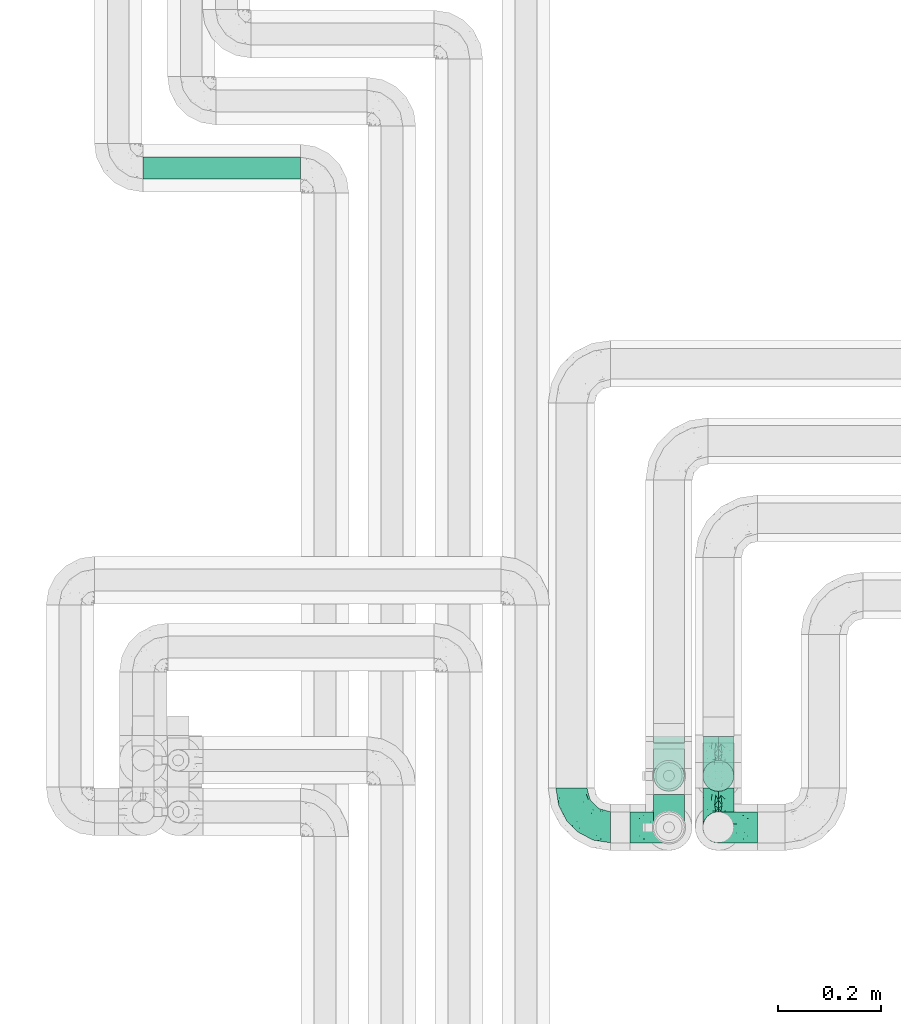
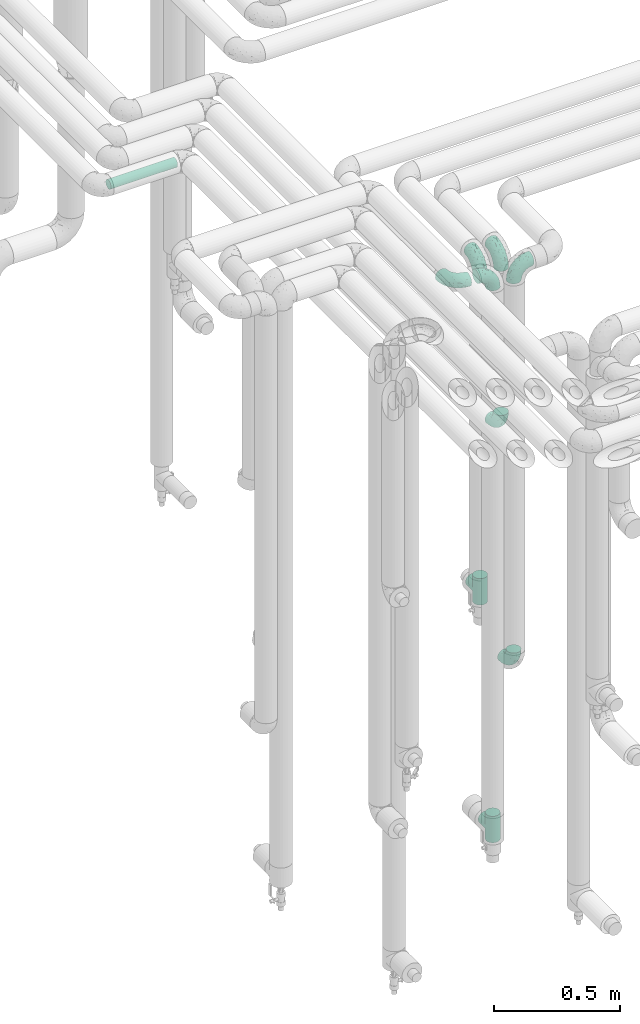
# One storey, part 633 of 827: 9 flow fittings, 1 flow segment.
"""IFC2X3 building model written with IfcOpenShell, lengths in millimetres."""

from ifc_helpers import new_model, entity, si_unit, converted_unit, derived_unit, direction, frame, origin, origin_2d_with_axis, place, context, subcontext, project, spatial, circle, extrude, faceted_brep, source, transform, mapped, material, type_object, type_shapes, element, save


model = new_model("IFC2X3")

# Units and contexts
model_context = context("Model", 3, precision=0.01, world=origin(), true_north=direction((6.12303176911189e-17, 1.0)))
body_context = subcontext(model_context, "Body", "Model", "MODEL_VIEW")
ifc_project = project(units=[si_unit("LENGTHUNIT", "METRE", prefix="MILLI"), si_unit("AREAUNIT", "SQUARE_METRE"), si_unit("VOLUMEUNIT", "CUBIC_METRE"), converted_unit("PLANEANGLEUNIT", "DEGREE", entity("IfcRatioMeasure", 0.0174532925199433), si_unit("PLANEANGLEUNIT", "RADIAN"), dimensions=[0, 0, 0, 0, 0, 0, 0]), si_unit("MASSUNIT", "GRAM", prefix="KILO"), derived_unit("MASSDENSITYUNIT", [(si_unit("MASSUNIT", "GRAM", prefix="KILO"), 1), (si_unit("LENGTHUNIT", "METRE"), -3)]), derived_unit("MOMENTOFINERTIAUNIT", [(si_unit("LENGTHUNIT", "METRE"), 4)]), si_unit("TIMEUNIT", "SECOND"), si_unit("FREQUENCYUNIT", "HERTZ"), si_unit("THERMODYNAMICTEMPERATUREUNIT", "DEGREE_CELSIUS"), derived_unit("THERMALTRANSMITTANCEUNIT", [(si_unit("MASSUNIT", "GRAM", prefix="KILO"), 1), (si_unit("THERMODYNAMICTEMPERATUREUNIT", "KELVIN"), -1), (si_unit("TIMEUNIT", "SECOND"), -3)]), derived_unit("VOLUMETRICFLOWRATEUNIT", [(si_unit("LENGTHUNIT", "METRE"), 3), (si_unit("TIMEUNIT", "SECOND"), -1)]), derived_unit("MASSFLOWRATEUNIT", [(si_unit("MASSUNIT", "GRAM", prefix="KILO"), 1), (si_unit("TIMEUNIT", "SECOND"), -1)]), derived_unit("ROTATIONALFREQUENCYUNIT", [(si_unit("TIMEUNIT", "SECOND"), -1)]), si_unit("ELECTRICCURRENTUNIT", "AMPERE"), si_unit("ELECTRICVOLTAGEUNIT", "VOLT"), si_unit("POWERUNIT", "WATT"), si_unit("FORCEUNIT", "NEWTON", prefix="KILO"), si_unit("ILLUMINANCEUNIT", "LUX"), si_unit("LUMINOUSFLUXUNIT", "LUMEN"), si_unit("LUMINOUSINTENSITYUNIT", "CANDELA"), derived_unit("USERDEFINED", [(si_unit("MASSUNIT", "GRAM", prefix="KILO"), -1), (si_unit("LENGTHUNIT", "METRE"), -2), (si_unit("TIMEUNIT", "SECOND"), 3), (si_unit("LUMINOUSFLUXUNIT", "LUMEN"), 1)]), derived_unit("LINEARVELOCITYUNIT", [(si_unit("LENGTHUNIT", "METRE"), 1), (si_unit("TIMEUNIT", "SECOND"), -1)]), si_unit("PRESSUREUNIT", "PASCAL"), derived_unit("USERDEFINED", [(si_unit("LENGTHUNIT", "METRE"), -2), (si_unit("MASSUNIT", "GRAM", prefix="KILO"), 1), (si_unit("TIMEUNIT", "SECOND"), -2)]), derived_unit("LINEARFORCEUNIT", [(si_unit("MASSUNIT", "GRAM", prefix="KILO"), 1), (si_unit("LENGTHUNIT", "METRE"), 1), (si_unit("TIMEUNIT", "SECOND"), -2), (si_unit("LENGTHUNIT", "METRE"), -1)]), derived_unit("PLANARFORCEUNIT", [(si_unit("MASSUNIT", "GRAM", prefix="KILO"), 1), (si_unit("LENGTHUNIT", "METRE"), 1), (si_unit("TIMEUNIT", "SECOND"), -2), (si_unit("LENGTHUNIT", "METRE"), -2)])], contexts=[model_context])

# Site, building, storey
site_placement = place(None, origin())
site = spatial("IfcSite", under=ifc_project, at=site_placement, CompositionType="ELEMENT")
building_placement = place(site_placement, origin())
building = spatial("IfcBuilding", under=site, at=building_placement, CompositionType="ELEMENT")
storey_placement = place(building_placement, frame((0.0, 0.0, 28200.0)))
storey = spatial("IfcBuildingStorey", under=building, at=storey_placement, Name="08", CompositionType="ELEMENT", Elevation=28200.0)

# Flow segment
pipe_segment_type = type_object("IfcPipeSegmentType", PredefinedType="NOTDEFINED")
flow_segment_placement = place(storey_placement, frame((30563.05, 16968.46, 2977.25)))
element("IfcFlowSegment", 1, at=flow_segment_placement, inside=storey, type_object=pipe_segment_type, context=body_context, shape_type="SweptSolid", body=[
    extrude(circle(Radius=21.15, at=origin_2d_with_axis()), frame((0.0, 22.75, 22.75), z_axis=(1.0, 0.0, 0.0), x_axis=(0.0, -1.0, 0.0)), (0.0, 0.0, 1.0), 305.473199999971),
])

# Flow fittings
ifc_material = material()
pipe_fitting_type_1 = type_object("IfcPipeFittingType", Name="ADSK_1", PredefinedType="NOTDEFINED", material=ifc_material)
shared_shape_1 = source(origin(), body_context, "Body", "Brep", [
    faceted_brep([(-76.0, 15.07, -26.11), (-76.0, 7.8, -29.12), (-76.0, 0.0, -30.15), (-76.0, -7.8, -29.12), (-76.0, -15.08, -26.11), (-76.0, -21.32, -21.32), (-76.0, -26.11, -15.08), (-76.0, -29.12, -7.8), (-76.0, -30.15, 0.0), (-76.0, -29.12, 7.8), (-76.0, -26.11, 15.07), (-76.0, -21.32, 21.32), (-76.0, -15.08, 26.11), (-76.0, -7.8, 29.12), (-76.0, 0.0, 30.15), (-76.0, 7.8, 29.12), (-76.0, 15.07, 26.11), (-76.0, 21.32, 21.32), (-76.0, 26.11, 15.07), (-76.0, 29.12, 7.8), (-76.0, 30.15, 0.0), (-76.0, 29.12, -7.8), (-76.0, 26.11, -15.08), (-76.0, 21.32, -21.32), (0.0, 76.0, -30.15), (-7.8, 76.0, -29.12), (-15.07, 76.0, -26.11), (-21.32, 76.0, -21.32), (-26.11, 76.0, -15.08), (-29.12, 76.0, -7.8), (-30.15, 76.0, 0.0), (-29.12, 76.0, 7.8), (-26.11, 76.0, 15.07), (-21.32, 76.0, 21.32), (-15.07, 76.0, 26.11), (-7.8, 76.0, 29.12), (0.0, 76.0, 30.15), (7.8, 76.0, 29.12), (15.08, 76.0, 26.11), (21.32, 76.0, 21.32), (26.11, 76.0, 15.07), (29.12, 76.0, 7.8), (30.15, 76.0, 0.0), (29.12, 76.0, -7.8), (26.11, 76.0, -15.08), (21.32, 76.0, -21.32), (15.08, 76.0, -26.11), (7.8, 76.0, -29.12), (10.79, 31.43, 21.07), (4.32, 31.7, 25.72), (1.65, 15.19, 19.92), (-61.17, -27.8, 0.0), (-51.1, -25.49, 9.84), (-56.14, -10.61, 27.27), (-31.7, -4.32, 25.72), (-39.75, 1.72, 29.41), (-43.2, -24.95, 0.0), (-1.86, 1.86, 0.0), (4.49, 7.65, 5.78), (-7.82, -4.61, 5.83), (-56.21, -22.79, 17.21), (-58.98, -3.38, 29.7), (-53.96, 5.6, 30.07), (-10.86, 10.86, 25.48), (-17.2, -2.6, 20.44), (-49.15, -16.01, 22.7), (-22.18, -14.24, 7.99), (-28.4, -17.42, 0.0), (-13.61, -9.88, 0.0), (-39.0, 23.48, 27.76), (-58.76, 12.54, 28.36), (-41.61, 15.41, 29.48), (16.01, 49.15, 22.7), (-58.55, 25.93, 19.53), (-51.53, 33.5, 13.51), (-64.92, 28.76, 12.4), (-7.48, 23.14, 28.25), (-1.72, 39.75, 29.41), (-12.04, 27.88, 29.88), (-63.91, 18.81, 24.52), (-11.63, 65.16, 28.18), (-4.97, 57.02, 30.05), (9.88, 13.61, 0.0), (-62.5, 31.74, 5.02), (-45.17, 30.98, 21.2), (-21.78, 9.76, 28.58), (10.61, 56.14, 27.27), (-32.09, 54.42, 13.26), (22.79, 56.21, 17.21), (15.38, 31.17, 15.63), (25.49, 51.1, 9.84), (21.84, 36.35, 5.92), (24.95, 43.2, 0.0), (3.38, 58.98, 29.7), (-31.17, -15.38, 15.63), (-39.39, 41.78, 15.45), (-34.56, 41.13, 20.79), (-39.81, -23.25, 5.49), (27.8, 61.17, 0.0), (-31.74, 62.5, 5.02), (-53.07, 36.29, 0.0), (-42.95, 42.95, 7.29), (-36.29, 53.07, 0.0), (-19.83, 58.51, 24.79), (-25.48, 60.2, 19.41), (-14.53, 50.96, 28.57), (-13.31, 37.09, 30.07), (-26.16, 40.06, 26.4), (-32.43, -10.35, 21.9), (17.42, 28.4, 0.0), (14.24, 22.18, 7.99), (-38.67, 9.72, 30.15), (-24.66, 17.36, 30.09), (-37.08, 31.49, 24.99), (-49.27, 22.83, 25.24), (-20.8, 38.81, 28.63), (-27.58, 27.58, 29.2), (-36.07, -20.23, 10.71), (-15.19, -6.16, 14.9), (6.6, 15.4, 14.49), (-2.51, 2.51, 11.35), (-65.16, 11.63, -28.18), (-49.15, -16.01, -22.7), (-57.02, 4.97, -30.05), (-25.93, 58.55, -19.53), (-33.5, 51.53, -13.51), (-28.76, 64.92, -12.4), (-60.2, 25.48, -19.41), (-58.51, 19.83, -24.79), (4.61, 7.82, -5.83), (-7.65, -4.49, -5.78), (-2.51, 2.51, -11.35), (-62.5, 31.74, -5.02), (-50.96, 14.53, -28.57), (-37.09, 13.31, -30.07), (-42.95, 42.95, -7.29), (25.49, 51.1, -9.84), (22.79, 56.21, -17.21), (-40.06, 26.16, -26.4), (3.38, 58.98, -29.7), (-5.6, 53.96, -30.07), (-27.88, 12.04, -29.88), (-9.76, 21.78, -28.58), (-23.14, 7.48, -28.25), (-51.1, -25.49, -9.84), (15.38, 31.17, -15.63), (16.01, 49.15, -22.7), (-23.48, 39.0, -27.76), (-12.54, 58.76, -28.36), (-15.41, 41.61, -29.48), (-56.21, -22.79, -17.21), (-9.72, 38.67, -30.15), (-17.36, 24.66, -30.09), (-22.18, -14.24, -7.99), (-41.13, 34.56, -20.79), (-31.74, 62.5, -5.02), (-58.98, -3.38, -29.7), (-31.17, -15.38, -15.63), (-56.14, -10.61, -27.27), (14.24, 22.18, -7.99), (23.25, 39.81, -5.49), (-31.49, 37.08, -24.99), (-15.19, -6.16, -14.9), (1.65, 15.19, -19.92), (-18.81, 63.91, -24.52), (-32.59, -11.62, -20.84), (-31.7, -4.32, -25.72), (-17.2, -2.6, -20.44), (-39.75, 1.72, -29.41), (-54.42, 32.09, -13.26), (-30.98, 45.17, -21.2), (10.61, 56.14, -27.27), (10.23, 31.31, -21.52), (4.32, 31.7, -25.72), (-41.78, 39.39, -15.45), (-1.72, 39.75, -29.41), (-36.35, -21.84, -5.92), (-22.83, 49.27, -25.24), (-38.81, 20.8, -28.63), (-27.58, 27.58, -29.2), (-10.86, 10.86, -25.48), (20.23, 36.07, -10.71), (6.6, 15.4, -14.49)], [[[0, 1, 2, 3, 4, 5, 6, 7, 8, 9, 10, 11, 12, 13, 14, 15, 16, 17, 18, 19, 20, 21, 22, 23]], [[24, 25, 26, 27, 28, 29, 30, 31, 32, 33, 34, 35, 36, 37, 38, 39, 40, 41, 42, 43, 44, 45, 46, 47]], [[48, 49, 50]], [[51, 52, 9]], [[53, 54, 55]], [[9, 52, 10]], [[56, 52, 51]], [[57, 58, 59]], [[11, 10, 60]], [[14, 61, 62]], [[63, 54, 64]], [[65, 12, 11]], [[65, 53, 12]], [[66, 67, 68]], [[69, 70, 71]], [[72, 39, 38]], [[73, 74, 75]], [[15, 70, 16]], [[76, 77, 78]], [[16, 79, 17]], [[13, 61, 14]], [[35, 80, 81]], [[14, 62, 15]], [[17, 73, 18]], [[57, 82, 58]], [[20, 19, 83]], [[75, 19, 18]], [[70, 15, 62]], [[73, 84, 74]], [[78, 85, 76]], [[38, 86, 72]], [[32, 31, 87]], [[88, 89, 90]], [[91, 92, 90]], [[72, 86, 49]], [[36, 93, 37]], [[75, 83, 19]], [[36, 35, 81]], [[60, 94, 65]], [[40, 90, 41]], [[95, 96, 87]], [[88, 90, 40]], [[66, 97, 67]], [[90, 98, 41]], [[40, 39, 88]], [[99, 31, 30]], [[20, 83, 100]], [[101, 102, 100]], [[52, 60, 10]], [[102, 99, 30]], [[96, 103, 104]], [[83, 101, 100]], [[12, 53, 13]], [[104, 103, 33]], [[105, 106, 81]], [[107, 105, 103]], [[64, 54, 108]], [[80, 103, 105]], [[80, 35, 34]], [[34, 33, 103]], [[86, 38, 37]], [[109, 110, 82]], [[71, 111, 112]], [[69, 107, 113]], [[79, 73, 17]], [[114, 113, 84]], [[33, 32, 104]], [[115, 107, 116]], [[105, 115, 106]], [[93, 81, 77]], [[54, 53, 65]], [[61, 53, 55]], [[108, 94, 64]], [[54, 63, 85]], [[93, 86, 37]], [[77, 76, 49]], [[77, 49, 86]], [[49, 63, 50]], [[60, 52, 117]], [[65, 11, 60]], [[39, 72, 88]], [[89, 88, 72]], [[71, 70, 62]], [[79, 70, 114]], [[103, 96, 107]], [[69, 113, 114]], [[112, 106, 116]], [[77, 81, 106]], [[112, 116, 71]], [[112, 55, 85]], [[64, 50, 63]], [[57, 59, 68]], [[32, 87, 104]], [[96, 104, 87]], [[94, 118, 64]], [[50, 119, 89]], [[50, 64, 118]], [[50, 89, 48]], [[81, 93, 36]], [[86, 93, 77]], [[53, 61, 13]], [[62, 61, 55]], [[71, 62, 111]], [[69, 71, 116]], [[95, 101, 74]], [[99, 101, 87]], [[118, 66, 59]], [[117, 97, 66]], [[117, 66, 94]], [[91, 89, 110]], [[91, 110, 109]], [[110, 89, 119]], [[9, 8, 51]], [[98, 90, 92]], [[98, 42, 41]], [[101, 83, 74]], [[101, 99, 102]], [[87, 31, 99]], [[62, 55, 111]], [[55, 112, 111]], [[107, 69, 116]], [[70, 69, 114]], [[107, 96, 113]], [[84, 113, 96]], [[84, 96, 95]], [[114, 84, 73]], [[70, 79, 16]], [[73, 79, 114]], [[54, 85, 55]], [[76, 85, 63]], [[49, 76, 63]], [[77, 106, 78]], [[106, 112, 78]], [[85, 78, 112]], [[73, 75, 18]], [[83, 75, 74]], [[103, 80, 34]], [[81, 80, 105]], [[101, 95, 87]], [[84, 95, 74]], [[106, 115, 116]], [[105, 107, 115]], [[120, 59, 58]], [[82, 110, 58]], [[119, 58, 110]], [[118, 59, 120]], [[66, 68, 59]], [[54, 65, 108]], [[94, 108, 65]], [[66, 118, 94]], [[50, 118, 120]], [[50, 120, 119]], [[119, 120, 58]], [[89, 72, 48]], [[49, 48, 72]], [[60, 117, 94]], [[117, 52, 97]], [[52, 56, 97]], [[67, 97, 56]], [[92, 91, 109]], [[89, 91, 90]], [[121, 1, 0]], [[122, 5, 4]], [[2, 1, 123]], [[124, 125, 126]], [[127, 128, 23]], [[129, 130, 131]], [[100, 132, 20]], [[133, 134, 123]], [[135, 100, 102]], [[136, 137, 44]], [[133, 128, 138]], [[24, 139, 140]], [[141, 142, 143]], [[121, 128, 133]], [[6, 144, 7]], [[137, 145, 146]], [[144, 51, 7]], [[147, 148, 149]], [[144, 6, 150]], [[149, 151, 152]], [[153, 68, 67]], [[154, 128, 127]], [[30, 155, 102]], [[43, 42, 98]], [[156, 3, 2]], [[157, 144, 150]], [[158, 4, 3]], [[24, 140, 25]], [[155, 135, 102]], [[159, 160, 109]], [[30, 29, 155]], [[147, 138, 161]], [[27, 124, 28]], [[57, 129, 82]], [[162, 163, 131]], [[27, 26, 164]], [[148, 26, 25]], [[165, 166, 167]], [[24, 47, 139]], [[143, 168, 141]], [[22, 21, 169]], [[125, 124, 170]], [[148, 25, 140]], [[46, 146, 171]], [[158, 122, 4]], [[0, 23, 128]], [[1, 121, 123]], [[109, 82, 159]], [[45, 44, 137]], [[146, 46, 45]], [[136, 43, 98]], [[132, 21, 20]], [[136, 98, 92]], [[172, 173, 146]], [[46, 171, 47]], [[43, 136, 44]], [[174, 154, 169]], [[171, 173, 175]], [[6, 5, 150]], [[126, 29, 28]], [[176, 56, 144]], [[122, 158, 166]], [[164, 124, 27]], [[177, 161, 170]], [[23, 22, 127]], [[178, 138, 179]], [[133, 178, 134]], [[156, 123, 168]], [[156, 158, 3]], [[168, 143, 166]], [[168, 166, 158]], [[166, 180, 167]], [[173, 171, 146]], [[139, 171, 175]], [[172, 145, 163]], [[173, 180, 142]], [[5, 122, 150]], [[157, 150, 122]], [[137, 136, 181]], [[146, 45, 137]], [[149, 148, 140]], [[164, 148, 177]], [[128, 154, 138]], [[147, 161, 177]], [[152, 134, 179]], [[168, 123, 134]], [[152, 179, 149]], [[152, 175, 142]], [[57, 130, 129]], [[157, 165, 167]], [[22, 169, 127]], [[154, 127, 169]], [[163, 167, 180]], [[162, 157, 167]], [[173, 163, 180]], [[182, 163, 145]], [[123, 156, 2]], [[158, 156, 168]], [[171, 139, 47]], [[140, 139, 175]], [[149, 140, 151]], [[147, 149, 179]], [[174, 135, 125]], [[132, 135, 169]], [[176, 157, 153]], [[176, 153, 67]], [[153, 157, 162]], [[182, 159, 129]], [[181, 160, 159]], [[181, 159, 145]], [[51, 144, 56]], [[51, 8, 7]], [[135, 132, 100]], [[169, 21, 132]], [[126, 155, 29]], [[135, 155, 125]], [[140, 175, 151]], [[175, 152, 151]], [[138, 147, 179]], [[148, 147, 177]], [[138, 154, 161]], [[170, 161, 154]], [[170, 154, 174]], [[177, 170, 124]], [[148, 164, 26]], [[124, 164, 177]], [[173, 142, 175]], [[143, 142, 180]], [[166, 143, 180]], [[168, 134, 141]], [[134, 152, 141]], [[142, 141, 152]], [[124, 126, 28]], [[155, 126, 125]], [[128, 121, 0]], [[123, 121, 133]], [[135, 174, 169]], [[170, 174, 125]], [[134, 178, 179]], [[133, 138, 178]], [[130, 153, 162]], [[68, 153, 130]], [[57, 68, 130]], [[182, 129, 131]], [[159, 82, 129]], [[157, 122, 165]], [[166, 165, 122]], [[163, 162, 167]], [[162, 131, 130]], [[145, 172, 146]], [[163, 173, 172]], [[159, 182, 145]], [[131, 163, 182]], [[56, 176, 67]], [[157, 176, 144]], [[137, 181, 145]], [[181, 136, 160]], [[136, 92, 160]], [[109, 160, 92]]]),
])
type_shapes(pipe_fitting_type_1, [shared_shape_1])
for number, where, z_axis, x_axis, name in (
    (2, (31395.03, 15711.2, 3000.0), (0.0, 0.0, 1.0), (0.0, -1.0, 0.0), "ADSK_1"),
    (3, (31680.25, 15711.2, 3000.0), (0.0, -1.0, 0.0), (-1.0, 0.0, 0.0), "ADSK_1"),
    (4, (31584.25, 15711.2, 3000.0), (0.0, 1.0, 0.0), (1.0, 0.0, 0.0), "ADSK_1"),
    (5, (31584.25, 15811.2, 3000.0), (1.0, 0.0, 0.0), (0.0, -1.0, 0.0), "ADSK_1"),
    (6, (31680.25, 15811.2, 3000.0), (1.0, 0.0, 0.0), (0.0, -1.0, 0.0), "ADSK_1"),
    (7, (31680.25, 15811.2, 2150.0), (1.0, 0.0, 0.0), (0.0, 0.0, -1.0), "ADSK_1"),
    (8, (31680.25, 15711.2, 1060.0), (1.0, 0.0, 0.0), (0.0, 0.0, -1.0), "ADSK_1"),
):
    element("IfcFlowFitting", number, at=place(storey_placement, frame(where, z_axis=z_axis, x_axis=x_axis)), inside=storey, type_object=pipe_fitting_type_1, material=ifc_material, Name=name, ObjectType="ADSK_1", context=body_context, shape_type="MappedRepresentation", body=[
        mapped(shared_shape_1, transform((0.0, 0.0, 0.0), scale=1.0)),
    ])
pipe_fitting_type_2 = type_object("IfcPipeFittingType", Name="ADSK_1", PredefinedType="NOTDEFINED", material=ifc_material)
shared_shape_2 = source(origin(), body_context, "Body", "Brep", [
    faceted_brep([(-64.0, 15.07, -26.11), (-64.0, 7.8, -29.12), (-64.0, 0.0, -30.15), (-64.0, -7.8, -29.12), (-64.0, -15.08, -26.11), (-64.0, -21.32, -21.32), (-64.0, -26.11, -15.08), (-64.0, -29.12, -7.8), (-64.0, -30.15, 0.0), (-64.0, -29.12, 7.8), (-64.0, -26.11, 15.07), (-64.0, -21.32, 21.32), (-64.0, -15.08, 26.11), (-64.0, -7.8, 29.12), (-64.0, 0.0, 30.15), (-64.0, 7.8, 29.12), (-64.0, 15.07, 26.11), (-64.0, 21.32, 21.32), (-64.0, 26.11, 15.07), (-64.0, 29.12, 7.8), (-64.0, 30.15, 0.0), (-64.0, 29.12, -7.8), (-64.0, 26.11, -15.08), (-64.0, 21.32, -21.32), (64.0, 0.0, -30.15), (64.0, 7.8, -29.12), (64.0, 15.07, -26.11), (64.0, 21.32, -21.32), (64.0, 26.11, -15.08), (64.0, 29.12, -7.8), (64.0, 30.15, 0.0), (64.0, 29.12, 7.8), (64.0, 26.11, 15.07), (64.0, 21.32, 21.32), (64.0, 15.07, 26.11), (64.0, 7.8, 29.12), (64.0, 0.0, 30.15), (64.0, -7.8, 29.12), (64.0, -15.08, 26.11), (64.0, -21.32, 21.32), (64.0, -26.11, 15.07), (64.0, -29.12, 7.8), (64.0, -30.15, 0.0), (64.0, -29.12, -7.8), (64.0, -26.11, -15.08), (64.0, -21.32, -21.32), (64.0, -15.08, -26.11), (64.0, -7.8, -29.12), (29.06, -29.06, 8.05), (30.15, -30.15, 0.0), (-30.15, -30.15, 0.0), (26.09, -26.09, 15.1), (16.9, -16.9, 24.97), (21.88, -21.88, 20.75), (-29.06, -29.06, 8.05), (-26.09, -26.09, 15.1), (-21.88, -21.88, 20.75), (-16.9, -16.9, 24.97), (-11.47, -11.47, 27.88), (11.47, -11.47, 27.88), (5.79, -5.79, 29.59), (0.0, 0.0, 30.15), (-5.79, -5.79, 29.59), (5.79, -5.79, -29.59), (0.0, 0.0, -30.15), (-5.79, -5.79, -29.59), (-11.47, -11.47, -27.88), (11.47, -11.47, -27.88), (16.9, -16.9, -24.97), (21.88, -21.88, -20.75), (26.09, -26.09, -15.1), (29.06, -29.06, -8.05), (-16.9, -16.9, -24.97), (-21.88, -21.88, -20.75), (-29.06, -29.06, -8.05), (-26.09, -26.09, -15.1), (0.0, -64.0, -30.15), (7.8, -64.0, -29.12), (15.08, -64.0, -26.11), (21.32, -64.0, -21.32), (26.11, -64.0, -15.08), (29.12, -64.0, -7.8), (30.15, -64.0, 0.0), (29.12, -64.0, 7.8), (26.11, -64.0, 15.07), (21.32, -64.0, 21.32), (15.08, -64.0, 26.11), (7.8, -64.0, 29.12), (0.0, -64.0, 30.15), (-7.8, -64.0, 29.12), (-15.07, -64.0, 26.11), (-21.32, -64.0, 21.32), (-26.11, -64.0, 15.07), (-29.12, -64.0, 7.8), (-30.15, -64.0, 0.0), (-29.12, -64.0, -7.8), (-26.11, -64.0, -15.08), (-21.32, -64.0, -21.32), (-15.07, -64.0, -26.11), (-7.8, -64.0, -29.12)], [[[0, 1, 2, 3, 4, 5, 6, 7, 8, 9, 10, 11, 12, 13, 14, 15, 16, 17, 18, 19, 20, 21, 22, 23]], [[24, 25, 26, 27, 28, 29, 30, 31, 32, 33, 34, 35, 36, 37, 38, 39, 40, 41, 42, 43, 44, 45, 46, 47]], [[41, 40, 48]], [[42, 41, 49]], [[50, 9, 8]], [[49, 41, 48]], [[40, 51, 48]], [[39, 38, 52]], [[51, 40, 53]], [[52, 53, 39]], [[53, 40, 39]], [[50, 54, 9]], [[9, 54, 10]], [[54, 55, 10]], [[56, 57, 11]], [[11, 10, 56]], [[11, 57, 12]], [[56, 10, 55]], [[12, 57, 58]], [[52, 38, 59]], [[60, 36, 61]], [[62, 61, 14]], [[59, 37, 60]], [[37, 59, 38]], [[60, 37, 36]], [[61, 36, 35, 15, 14]], [[32, 31, 19, 18]], [[17, 16, 34, 33]], [[18, 17, 33, 32]], [[35, 34, 16, 15]], [[20, 19, 31, 30]], [[62, 13, 58]], [[13, 62, 14]], [[58, 13, 12]], [[27, 23, 22, 28]], [[22, 21, 29, 28]], [[0, 23, 27, 26]], [[20, 30, 29, 21]], [[24, 47, 63]], [[24, 64, 2, 1, 25]], [[64, 24, 63]], [[2, 64, 65]], [[26, 25, 1, 0]], [[65, 66, 3]], [[2, 65, 3]], [[66, 4, 3]], [[63, 47, 67]], [[46, 45, 68]], [[69, 68, 45]], [[44, 70, 69]], [[69, 45, 44]], [[46, 68, 67]], [[43, 42, 49]], [[7, 50, 8]], [[43, 71, 44]], [[71, 43, 49]], [[44, 71, 70]], [[72, 4, 66]], [[72, 5, 4]], [[5, 72, 73]], [[5, 73, 6]], [[74, 50, 7]], [[75, 74, 6]], [[74, 7, 6]], [[75, 6, 73]], [[46, 67, 47]], [[76, 77, 78, 79, 80, 81, 82, 83, 84, 85, 86, 87, 88, 89, 90, 91, 92, 93, 94, 95, 96, 97, 98, 99]], [[50, 94, 93]], [[54, 50, 93]], [[91, 90, 57]], [[56, 92, 91]], [[54, 93, 92]], [[58, 90, 89]], [[55, 54, 92]], [[56, 55, 92]], [[58, 57, 90]], [[88, 61, 62]], [[58, 89, 62]], [[56, 91, 57]], [[62, 89, 88]], [[60, 88, 87]], [[86, 59, 87]], [[84, 83, 48]], [[53, 85, 84]], [[52, 86, 85]], [[49, 83, 82]], [[59, 60, 87]], [[52, 59, 86]], [[49, 48, 83]], [[51, 53, 84]], [[48, 51, 84]], [[52, 85, 53]], [[88, 60, 61]], [[82, 81, 49]], [[71, 49, 81]], [[69, 80, 79]], [[79, 78, 68]], [[71, 81, 80]], [[67, 78, 77]], [[70, 71, 80]], [[69, 70, 80]], [[67, 68, 78]], [[76, 64, 63]], [[67, 77, 63]], [[69, 79, 68]], [[63, 77, 76]], [[65, 76, 99]], [[98, 66, 99]], [[96, 95, 74]], [[73, 97, 96]], [[72, 98, 97]], [[50, 95, 94]], [[66, 65, 99]], [[72, 66, 98]], [[50, 74, 95]], [[75, 73, 96]], [[74, 75, 96]], [[72, 97, 73]], [[76, 65, 64]]]),
])
type_shapes(pipe_fitting_type_2, [shared_shape_2])
for number, where, z_axis, x_axis, name in (
    (9, (31584.25, 15711.2, 315.5), (-1.0, 0.0, 0.0), (0.0, 0.0, -1.0), "ADSK_1"),
    (10, (31584.25, 15811.2, 1405.5), (-1.0, 0.0, 0.0), (0.0, 0.0, -1.0), "ADSK_1"),
):
    element("IfcFlowFitting", number, at=place(storey_placement, frame(where, z_axis=z_axis, x_axis=x_axis)), inside=storey, type_object=pipe_fitting_type_2, material=ifc_material, Name=name, ObjectType="ADSK_1", context=body_context, shape_type="MappedRepresentation", body=[
        mapped(shared_shape_2, transform((0.0, 0.0, 0.0), scale=1.0)),
    ])

save(model, "model.ifc")
